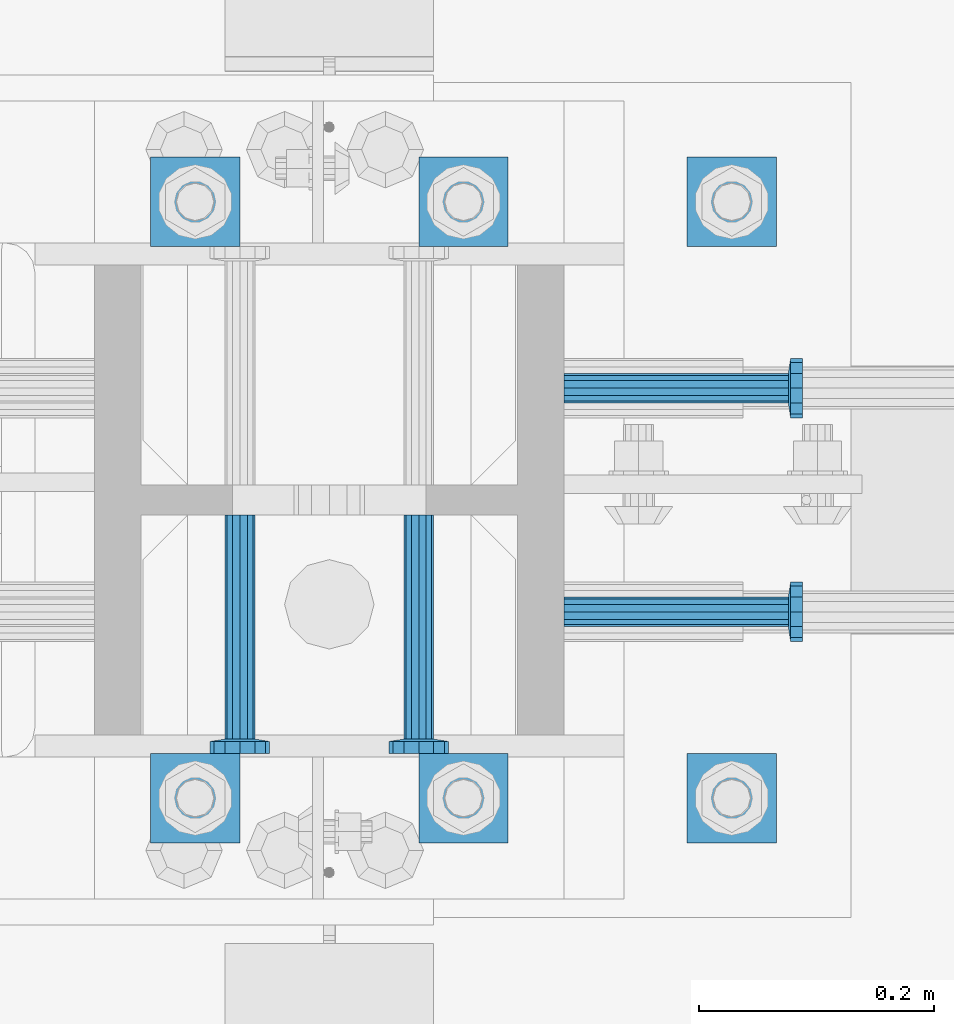
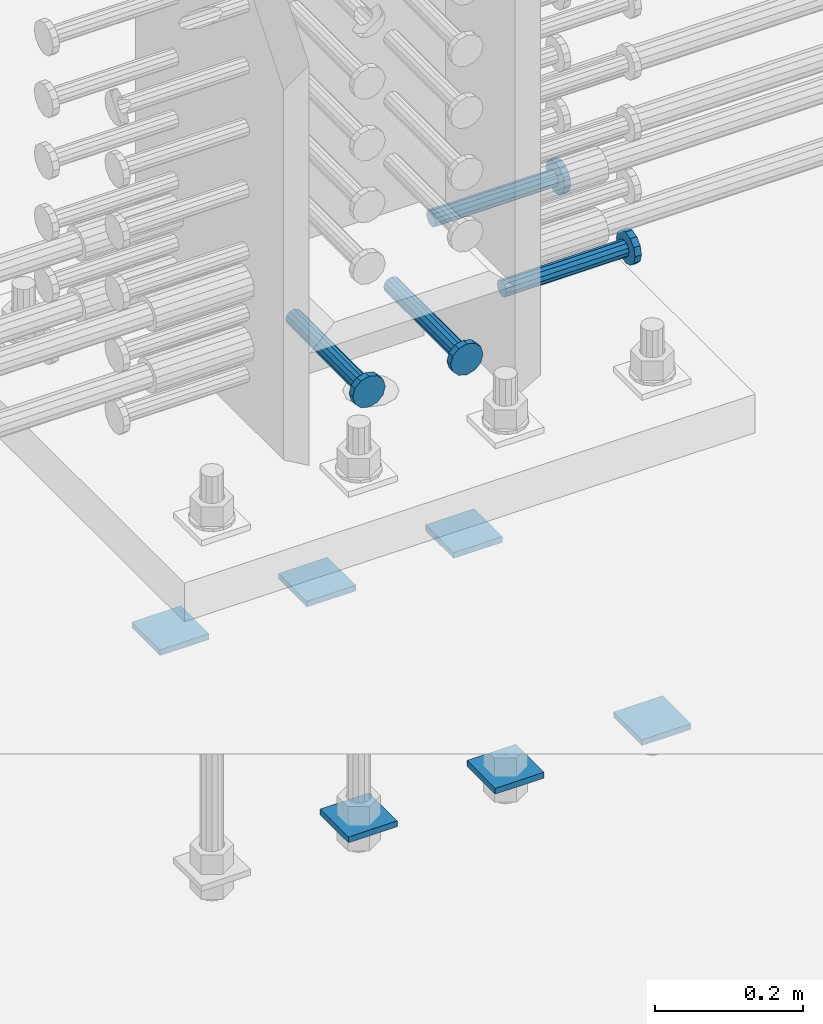
# One storey, part 1246 of 1763: 10 beams, 2 elements without a shape of their own.
"""IFC2X3 building model written with IfcOpenShell, lengths in millimetres."""

from ifc_helpers import new_model, si_unit, frame, origin_with_axes, place, context, subcontext, project, spatial, faceted_brep, material, type_object, element, aggregate, save


model = new_model("IFC2X3")

# Units and contexts
model_context = context("Model", 3, precision=1e-05, world=origin_with_axes())
body_context = subcontext(model_context, "Body", "Model", "MODEL_VIEW")
ifc_project = project(units=[si_unit("LENGTHUNIT", "METRE", prefix="MILLI"), si_unit("AREAUNIT", "SQUARE_METRE"), si_unit("VOLUMEUNIT", "CUBIC_METRE"), si_unit("MASSUNIT", "GRAM", prefix="KILO"), si_unit("TIMEUNIT", "SECOND"), si_unit("PLANEANGLEUNIT", "RADIAN"), si_unit("SOLIDANGLEUNIT", "STERADIAN"), si_unit("THERMODYNAMICTEMPERATUREUNIT", "DEGREE_CELSIUS"), si_unit("LUMINOUSINTENSITYUNIT", "LUMEN")], contexts=[model_context])

# Site, building, storey
site_placement = place(None, origin_with_axes())
site = spatial("IfcSite", under=ifc_project, at=site_placement, CompositionType="ELEMENT")
building_placement = place(site_placement, origin_with_axes())
building = spatial("IfcBuilding", under=site, at=building_placement, Name="Undefined", CompositionType="ELEMENT")
storey_placement = place(building_placement, origin_with_axes())
storey = spatial("IfcBuildingStorey", under=building, at=storey_placement, Name="Undefined", CompositionType="ELEMENT", Elevation=0.0)

# Assembly, beams
assembly_1_placement = place(storey_placement, origin_with_axes())
assembly_1 = element("IfcElementAssembly", 1, at=assembly_1_placement, inside=storey, Name="TEMPLATE", AssemblyPlace="NOTDEFINED", PredefinedType="RIGID_FRAME")
ifc_material_1 = material(Name="STEEL/A36")
beam_type_1 = type_object("IfcBeamType", PredefinedType="NOTDEFINED")
beam_1_placement = place(assembly_1_placement, frame((-34568.837273698, 203.199999999951, 3348.0375), z_axis=(0.0, 1.0, 0.0), x_axis=(-1.0, 0.0, 0.0)))
beam_1 = element("IfcBeam", 2, at=beam_1_placement, type_object=beam_type_1, material=ifc_material_1, Name="WASHER PLATE", context=body_context, shape_type="Brep", body=[
    faceted_brep([(0.0, 4.76249999999709, -38.1000000000004), (0.0, 4.76249999999709, 38.1000000000004), (76.2000000000007, 4.76249999999982, 38.0999999999985), (76.2000000000007, 4.76249999999982, -38.0999999999985), (0.0, -4.76249999999709, 38.1000000000004), (76.2000000000007, -4.76249999999982, 38.0999999999985), (0.0, -4.76249999999709, -38.1000000000004), (76.2000000000007, -4.76249999999982, -38.0999999999985)], [[[0, 1, 2, 3]], [[1, 4, 5, 2]], [[4, 6, 7, 5]], [[6, 0, 3, 7]], [[5, 7, 3, 2]], [[6, 4, 1, 0]]]),
])
beam_2_placement = place(assembly_1_placement, frame((-34568.837273698, 711.199999999951, 3348.0375), z_axis=(0.0, 1.0, 0.0), x_axis=(-1.0, 0.0, 0.0)))
beam_2 = element("IfcBeam", 3, at=beam_2_placement, type_object=beam_type_1, material=ifc_material_1, Name="WASHER PLATE", context=body_context, shape_type="Brep", body=[
    faceted_brep([(0.0, 4.76249999999709, -38.1000000000004), (0.0, 4.76249999999709, 38.1000000000004), (76.2000000000007, 4.76249999999982, 38.0999999999985), (76.2000000000007, 4.76249999999982, -38.0999999999985), (0.0, -4.76249999999709, 38.1000000000004), (76.2000000000007, -4.76249999999982, 38.0999999999985), (0.0, -4.76249999999709, -38.1000000000004), (76.2000000000007, -4.76249999999982, -38.0999999999985)], [[[0, 1, 2, 3]], [[1, 4, 5, 2]], [[4, 6, 7, 5]], [[6, 0, 3, 7]], [[5, 7, 3, 2]], [[6, 4, 1, 0]]]),
])
beam_3_placement = place(assembly_1_placement, frame((-34797.437273698, 203.199999999951, 3348.0375), z_axis=(0.0, 1.0, 0.0), x_axis=(-1.0, 0.0, 0.0)))
beam_3 = element("IfcBeam", 4, at=beam_3_placement, type_object=beam_type_1, material=ifc_material_1, Name="WASHER PLATE", context=body_context, shape_type="Brep", body=[
    faceted_brep([(0.0, 4.76249999999709, -38.1000000000004), (0.0, 4.76249999999709, 38.1000000000004), (76.2000000000007, 4.76249999999982, 38.0999999999985), (76.2000000000007, 4.76249999999982, -38.0999999999985), (0.0, -4.76249999999709, 38.1000000000004), (76.2000000000007, -4.76249999999982, 38.0999999999985), (0.0, -4.76249999999709, -38.1000000000004), (76.2000000000007, -4.76249999999982, -38.0999999999985)], [[[0, 1, 2, 3]], [[1, 4, 5, 2]], [[4, 6, 7, 5]], [[6, 0, 3, 7]], [[5, 7, 3, 2]], [[6, 4, 1, 0]]]),
])
beam_4_placement = place(assembly_1_placement, frame((-34797.437273698, 711.199999999951, 3348.0375), z_axis=(0.0, 1.0, 0.0), x_axis=(-1.0, 0.0, 0.0)))
beam_4 = element("IfcBeam", 5, at=beam_4_placement, type_object=beam_type_1, material=ifc_material_1, Name="WASHER PLATE", context=body_context, shape_type="Brep", body=[
    faceted_brep([(0.0, 4.76249999999709, -38.1000000000004), (0.0, 4.76249999999709, 38.1000000000004), (76.2000000000007, 4.76249999999982, 38.0999999999985), (76.2000000000007, 4.76249999999982, -38.0999999999985), (0.0, -4.76249999999709, 38.1000000000004), (76.2000000000007, -4.76249999999982, 38.0999999999985), (0.0, -4.76249999999709, -38.1000000000004), (76.2000000000007, -4.76249999999982, -38.0999999999985)], [[[0, 1, 2, 3]], [[1, 4, 5, 2]], [[4, 6, 7, 5]], [[6, 0, 3, 7]], [[5, 7, 3, 2]], [[6, 4, 1, 0]]]),
])
beam_5_placement = place(assembly_1_placement, frame((-35026.037273698, 203.199999999951, 3348.0375), z_axis=(0.0, 1.0, 0.0), x_axis=(-1.0, 0.0, 0.0)))
beam_5 = element("IfcBeam", 6, at=beam_5_placement, type_object=beam_type_1, material=ifc_material_1, Name="WASHER PLATE", context=body_context, shape_type="Brep", body=[
    faceted_brep([(0.0, 4.76249999999709, -38.1000000000004), (0.0, 4.76249999999709, 38.1000000000004), (76.2000000000007, 4.76249999999982, 38.0999999999985), (76.2000000000007, 4.76249999999982, -38.0999999999985), (0.0, -4.76249999999709, 38.1000000000004), (76.2000000000007, -4.76249999999982, 38.0999999999985), (0.0, -4.76249999999709, -38.1000000000004), (76.2000000000007, -4.76249999999982, -38.0999999999985)], [[[0, 1, 2, 3]], [[1, 4, 5, 2]], [[4, 6, 7, 5]], [[6, 0, 3, 7]], [[5, 7, 3, 2]], [[6, 4, 1, 0]]]),
])
beam_6_placement = place(assembly_1_placement, frame((-35026.037273698, 711.199999999951, 3348.0375), z_axis=(0.0, 1.0, 0.0), x_axis=(-1.0, 0.0, 0.0)))
beam_6 = element("IfcBeam", 7, at=beam_6_placement, type_object=beam_type_1, material=ifc_material_1, Name="WASHER PLATE", context=body_context, shape_type="Brep", body=[
    faceted_brep([(0.0, 4.76249999999709, -38.1000000000004), (0.0, 4.76249999999709, 38.1000000000004), (76.2000000000007, 4.76249999999982, 38.0999999999985), (76.2000000000007, 4.76249999999982, -38.0999999999985), (0.0, -4.76249999999709, 38.1000000000004), (76.2000000000007, -4.76249999999982, 38.0999999999985), (0.0, -4.76249999999709, -38.1000000000004), (76.2000000000007, -4.76249999999982, -38.0999999999985)], [[[0, 1, 2, 3]], [[1, 4, 5, 2]], [[4, 6, 7, 5]], [[6, 0, 3, 7]], [[5, 7, 3, 2]], [[6, 4, 1, 0]]]),
])
aggregate(assembly_1, [beam_1, beam_2, beam_3, beam_4, beam_5, beam_6])

assembly_2_placement = place(storey_placement, origin_with_axes())
assembly_2 = element("IfcElementAssembly", 8, at=assembly_2_placement, inside=storey, Name="COLUMN", AssemblyPlace="NOTDEFINED", PredefinedType="RIGID_FRAME")
ifc_material_2 = material(Name="STEEL/A108")
beam_type_2 = type_object("IfcBeamType", PredefinedType="NOTDEFINED")
beam_7_placement = place(assembly_2_placement, frame((-35026.0372733561, 444.499999885675, 4013.2), z_axis=(1.0, 0.0, 0.0), x_axis=(0.0, -1.0, 0.0)))
beam_7 = element("IfcBeam", 9, at=beam_7_placement, type_object=beam_type_2, material=ifc_material_2, Name="HEADED STUD ANCHOR", context=body_context, shape_type="Brep", body=[
    faceted_brep([(0.0, -12.6999999999971, -1.81898940354586e-12), (3.63797880709171e-12, -11.0, -6.34999990463257), (191.00799999576, -11.0, -6.34999990454889), (191.007999995752, -12.6999998092651, 8.36735125631094e-11), (7.27595761418343e-12, -6.34999990463257, -11.0), (191.00799999576, -6.34999990463257, -10.9999999999163), (3.63797880709171e-12, 0.0, -12.6999998092651), (191.00799999576, 0.0, -12.6999998091815), (7.27595761418343e-12, 6.34999990463257, -11.0), (191.00799999576, 6.34999990463257, -10.9999999999163), (3.63797880709171e-12, 11.0, -6.34999990463257), (191.00799999576, 11.0, -6.34999990454889), (0.0, 12.6999999999971, -1.81898940354586e-12), (191.007999995752, 12.6999998092651, 8.36735125631094e-11), (0.0, 11.0, 6.34999990463257), (191.007999995752, 11.0, 6.34999990471624), (-3.63797880709171e-12, 6.34999990463257, 11.0), (191.007999995749, 6.34999990463257, 11.0000000000837), (-3.63797880709171e-12, 0.0, 12.6999998092651), (191.007999995749, 0.0, 12.6999998093488), (-3.63797880709171e-12, -6.34999990463257, 11.0), (191.007999995749, -6.34999990463257, 11.0000000000837), (0.0, -11.0, 6.34999990463257), (191.007999995752, -11.0, 6.34999990471624), (193.039999995715, -22.0, -12.6999998091796), (193.039999995708, -25.3999996185303, 8.54925019666553e-11), (193.039999995719, -12.6999998092651, -21.9999999999145), (193.039999995719, 0.0, -25.3999996184448), (193.039999995719, 12.6999998092651, -21.9999999999145), (193.039999995715, 22.0, -12.6999998091796), (193.039999995708, 25.3999996185303, 8.54925019666553e-11), (193.039999995704, 22.0, 12.6999998093506), (193.039999995701, 12.6999998092651, 22.0000000000855), (193.039999995697, 0.0, 25.3999996186158), (193.039999995701, -12.6999998092651, 22.0000000000855), (193.039999995704, -22.0, 12.6999998093506), (203.199999995486, -22.0, -12.6999998091742), (203.199999995482, -25.3999996185303, 9.09494701772928e-11), (203.199999995493, -12.6999998092651, -21.9999999999091), (203.199999995493, 0.0, -25.3999996184393), (203.199999995493, 12.6999998092651, -21.9999999999091), (203.199999995486, 22.0, -12.6999998091742), (203.199999995482, 25.3999996185303, 9.09494701772928e-11), (203.199999995479, 22.0, 12.6999998093561), (203.199999995475, 12.6999998092651, 22.0000000000909), (203.199999995471, 0.0, 25.3999996186212), (203.199999995475, -12.6999998092651, 22.0000000000909), (203.199999995479, -22.0, 12.6999998093561)], [[[0, 1, 2, 3]], [[1, 4, 5, 2]], [[4, 6, 7, 5]], [[6, 8, 9, 7]], [[8, 10, 11, 9]], [[10, 12, 13, 11]], [[12, 14, 15, 13]], [[14, 16, 17, 15]], [[16, 18, 19, 17]], [[18, 20, 21, 19]], [[20, 22, 23, 21]], [[22, 0, 3, 23]], [[22, 20, 18, 16, 14, 12, 10, 8, 6, 4, 1, 0]], [[3, 2, 24, 25]], [[2, 5, 26, 24]], [[5, 7, 27, 26]], [[7, 9, 28, 27]], [[9, 11, 29, 28]], [[11, 13, 30, 29]], [[13, 15, 31, 30]], [[15, 17, 32, 31]], [[17, 19, 33, 32]], [[19, 21, 34, 33]], [[21, 23, 35, 34]], [[23, 3, 25, 35]], [[25, 24, 36, 37]], [[24, 26, 38, 36]], [[26, 27, 39, 38]], [[27, 28, 40, 39]], [[28, 29, 41, 40]], [[29, 30, 42, 41]], [[30, 31, 43, 42]], [[31, 32, 44, 43]], [[32, 33, 45, 44]], [[33, 34, 46, 45]], [[34, 35, 47, 46]], [[35, 25, 37, 47]], [[38, 39, 40, 41, 42, 43, 44, 45, 46, 47, 37, 36]]]),
])
beam_8_placement = place(assembly_2_placement, frame((-34873.637273357, 444.499999999951, 4013.2), z_axis=(1.0, 0.0, 0.0), x_axis=(0.0, -1.0, 0.0)))
beam_8 = element("IfcBeam", 10, at=beam_8_placement, type_object=beam_type_2, material=ifc_material_2, Name="HEADED STUD ANCHOR", context=body_context, shape_type="Brep", body=[
    faceted_brep([(0.0, -12.6999999999971, -1.81898940354586e-12), (3.63797880709171e-12, -11.0, -6.34999990463257), (191.00799999576, -11.0, -6.34999990454889), (191.007999995752, -12.6999998092651, 8.36735125631094e-11), (7.27595761418343e-12, -6.34999990463257, -11.0), (191.00799999576, -6.34999990463257, -10.9999999999163), (3.63797880709171e-12, 0.0, -12.6999998092651), (191.00799999576, 0.0, -12.6999998091815), (7.27595761418343e-12, 6.34999990463257, -11.0), (191.00799999576, 6.34999990463257, -10.9999999999163), (3.63797880709171e-12, 11.0, -6.34999990463257), (191.00799999576, 11.0, -6.34999990454889), (0.0, 12.6999999999971, -1.81898940354586e-12), (191.007999995752, 12.6999998092651, 8.36735125631094e-11), (0.0, 11.0, 6.34999990463257), (191.007999995752, 11.0, 6.34999990471624), (-3.63797880709171e-12, 6.34999990463257, 11.0), (191.007999995749, 6.34999990463257, 11.0000000000837), (-3.63797880709171e-12, 0.0, 12.6999998092651), (191.007999995749, 0.0, 12.6999998093488), (-3.63797880709171e-12, -6.34999990463257, 11.0), (191.007999995749, -6.34999990463257, 11.0000000000837), (0.0, -11.0, 6.34999990463257), (191.007999995752, -11.0, 6.34999990471624), (193.039999995715, -22.0, -12.6999998091796), (193.039999995708, -25.3999996185303, 8.54925019666553e-11), (193.039999995719, -12.6999998092651, -21.9999999999145), (193.039999995719, 0.0, -25.3999996184448), (193.039999995719, 12.6999998092651, -21.9999999999145), (193.039999995715, 22.0, -12.6999998091796), (193.039999995708, 25.3999996185303, 8.54925019666553e-11), (193.039999995704, 22.0, 12.6999998093506), (193.039999995701, 12.6999998092651, 22.0000000000855), (193.039999995697, 0.0, 25.3999996186158), (193.039999995701, -12.6999998092651, 22.0000000000855), (193.039999995704, -22.0, 12.6999998093506), (203.199999995486, -22.0, -12.6999998091742), (203.199999995482, -25.3999996185303, 9.09494701772928e-11), (203.199999995493, -12.6999998092651, -21.9999999999091), (203.199999995493, 0.0, -25.3999996184393), (203.199999995493, 12.6999998092651, -21.9999999999091), (203.199999995486, 22.0, -12.6999998091742), (203.199999995482, 25.3999996185303, 9.09494701772928e-11), (203.199999995479, 22.0, 12.6999998093561), (203.199999995475, 12.6999998092651, 22.0000000000909), (203.199999995471, 0.0, 25.3999996186212), (203.199999995475, -12.6999998092651, 22.0000000000909), (203.199999995479, -22.0, 12.6999998093561)], [[[0, 1, 2, 3]], [[1, 4, 5, 2]], [[4, 6, 7, 5]], [[6, 8, 9, 7]], [[8, 10, 11, 9]], [[10, 12, 13, 11]], [[12, 14, 15, 13]], [[14, 16, 17, 15]], [[16, 18, 19, 17]], [[18, 20, 21, 19]], [[20, 22, 23, 21]], [[22, 0, 3, 23]], [[22, 20, 18, 16, 14, 12, 10, 8, 6, 4, 1, 0]], [[3, 2, 24, 25]], [[2, 5, 26, 24]], [[5, 7, 27, 26]], [[7, 9, 28, 27]], [[9, 11, 29, 28]], [[11, 13, 30, 29]], [[13, 15, 31, 30]], [[15, 17, 32, 31]], [[17, 19, 33, 32]], [[19, 21, 34, 33]], [[21, 23, 35, 34]], [[23, 3, 25, 35]], [[25, 24, 36, 37]], [[24, 26, 38, 36]], [[26, 27, 39, 38]], [[27, 28, 40, 39]], [[28, 29, 41, 40]], [[29, 30, 42, 41]], [[30, 31, 43, 42]], [[31, 32, 44, 43]], [[32, 33, 45, 44]], [[33, 34, 46, 45]], [[34, 35, 47, 46]], [[35, 25, 37, 47]], [[38, 39, 40, 41, 42, 43, 44, 45, 46, 47, 37, 36]]]),
])
beam_9_placement = place(assembly_2_placement, frame((-34749.8119785861, 361.950000000554, 4013.2), z_axis=(0.0, 1.0, 0.0), x_axis=(1.0, 0.0, 0.0)))
beam_9 = element("IfcBeam", 11, at=beam_9_placement, type_object=beam_type_2, material=ifc_material_2, Name="HEADED STUD ANCHOR", context=body_context, shape_type="Brep", body=[
    faceted_brep([(0.0, -12.6999999999971, -1.81898940354586e-12), (3.63797880709171e-12, -11.0, -6.34999990463257), (191.00799999576, -11.0, -6.34999990454889), (191.007999995752, -12.6999998092651, 8.36735125631094e-11), (7.27595761418343e-12, -6.34999990463257, -11.0), (191.00799999576, -6.34999990463257, -10.9999999999163), (3.63797880709171e-12, 0.0, -12.6999998092651), (191.00799999576, 0.0, -12.6999998091815), (7.27595761418343e-12, 6.34999990463257, -11.0), (191.00799999576, 6.34999990463257, -10.9999999999163), (3.63797880709171e-12, 11.0, -6.34999990463257), (191.00799999576, 11.0, -6.34999990454889), (0.0, 12.6999999999971, -1.81898940354586e-12), (191.007999995752, 12.6999998092651, 8.36735125631094e-11), (0.0, 11.0, 6.34999990463257), (191.007999995752, 11.0, 6.34999990471624), (-3.63797880709171e-12, 6.34999990463257, 11.0), (191.007999995749, 6.34999990463257, 11.0000000000837), (-3.63797880709171e-12, 0.0, 12.6999998092651), (191.007999995749, 0.0, 12.6999998093488), (-3.63797880709171e-12, -6.34999990463257, 11.0), (191.007999995749, -6.34999990463257, 11.0000000000837), (0.0, -11.0, 6.34999990463257), (191.007999995752, -11.0, 6.34999990471624), (193.039999995715, -22.0, -12.6999998091796), (193.039999995708, -25.3999996185303, 8.54925019666553e-11), (193.039999995719, -12.6999998092651, -21.9999999999145), (193.039999995719, 0.0, -25.3999996184448), (193.039999995719, 12.6999998092651, -21.9999999999145), (193.039999995715, 22.0, -12.6999998091796), (193.039999995708, 25.3999996185303, 8.54925019666553e-11), (193.039999995704, 22.0, 12.6999998093506), (193.039999995701, 12.6999998092651, 22.0000000000855), (193.039999995697, 0.0, 25.3999996186158), (193.039999995701, -12.6999998092651, 22.0000000000855), (193.039999995704, -22.0, 12.6999998093506), (203.199999995486, -22.0, -12.6999998091742), (203.199999995482, -25.3999996185303, 9.09494701772928e-11), (203.199999995493, -12.6999998092651, -21.9999999999091), (203.199999995493, 0.0, -25.3999996184393), (203.199999995493, 12.6999998092651, -21.9999999999091), (203.199999995486, 22.0, -12.6999998091742), (203.199999995482, 25.3999996185303, 9.09494701772928e-11), (203.199999995479, 22.0, 12.6999998093561), (203.199999995475, 12.6999998092651, 22.0000000000909), (203.199999995471, 0.0, 25.3999996186212), (203.199999995475, -12.6999998092651, 22.0000000000909), (203.199999995479, -22.0, 12.6999998093561)], [[[0, 1, 2, 3]], [[1, 4, 5, 2]], [[4, 6, 7, 5]], [[6, 8, 9, 7]], [[8, 10, 11, 9]], [[10, 12, 13, 11]], [[12, 14, 15, 13]], [[14, 16, 17, 15]], [[16, 18, 19, 17]], [[18, 20, 21, 19]], [[20, 22, 23, 21]], [[22, 0, 3, 23]], [[22, 20, 18, 16, 14, 12, 10, 8, 6, 4, 1, 0]], [[3, 2, 24, 25]], [[2, 5, 26, 24]], [[5, 7, 27, 26]], [[7, 9, 28, 27]], [[9, 11, 29, 28]], [[11, 13, 30, 29]], [[13, 15, 31, 30]], [[15, 17, 32, 31]], [[17, 19, 33, 32]], [[19, 21, 34, 33]], [[21, 23, 35, 34]], [[23, 3, 25, 35]], [[25, 24, 36, 37]], [[24, 26, 38, 36]], [[26, 27, 39, 38]], [[27, 28, 40, 39]], [[28, 29, 41, 40]], [[29, 30, 42, 41]], [[30, 31, 43, 42]], [[31, 32, 44, 43]], [[32, 33, 45, 44]], [[33, 34, 46, 45]], [[34, 35, 47, 46]], [[35, 25, 37, 47]], [[38, 39, 40, 41, 42, 43, 44, 45, 46, 47, 37, 36]]]),
])
beam_10_placement = place(assembly_2_placement, frame((-34749.8119099256, 552.449999999943, 4013.2), z_axis=(0.0, 1.0, 0.0), x_axis=(1.0, 0.0, 0.0)))
beam_10 = element("IfcBeam", 12, at=beam_10_placement, type_object=beam_type_2, material=ifc_material_2, Name="HEADED STUD ANCHOR", context=body_context, shape_type="Brep", body=[
    faceted_brep([(0.0, -12.6999999999971, -1.81898940354586e-12), (3.63797880709171e-12, -11.0, -6.34999990463257), (191.00799999576, -11.0, -6.34999990454889), (191.007999995752, -12.6999998092651, 8.36735125631094e-11), (7.27595761418343e-12, -6.34999990463257, -11.0), (191.00799999576, -6.34999990463257, -10.9999999999163), (3.63797880709171e-12, 0.0, -12.6999998092651), (191.00799999576, 0.0, -12.6999998091815), (7.27595761418343e-12, 6.34999990463257, -11.0), (191.00799999576, 6.34999990463257, -10.9999999999163), (3.63797880709171e-12, 11.0, -6.34999990463257), (191.00799999576, 11.0, -6.34999990454889), (0.0, 12.6999999999971, -1.81898940354586e-12), (191.007999995752, 12.6999998092651, 8.36735125631094e-11), (0.0, 11.0, 6.34999990463257), (191.007999995752, 11.0, 6.34999990471624), (-3.63797880709171e-12, 6.34999990463257, 11.0), (191.007999995749, 6.34999990463257, 11.0000000000837), (-3.63797880709171e-12, 0.0, 12.6999998092651), (191.007999995749, 0.0, 12.6999998093488), (-3.63797880709171e-12, -6.34999990463257, 11.0), (191.007999995749, -6.34999990463257, 11.0000000000837), (0.0, -11.0, 6.34999990463257), (191.007999995752, -11.0, 6.34999990471624), (193.039999995715, -22.0, -12.6999998091796), (193.039999995708, -25.3999996185303, 8.54925019666553e-11), (193.039999995719, -12.6999998092651, -21.9999999999145), (193.039999995719, 0.0, -25.3999996184448), (193.039999995719, 12.6999998092651, -21.9999999999145), (193.039999995715, 22.0, -12.6999998091796), (193.039999995708, 25.3999996185303, 8.54925019666553e-11), (193.039999995704, 22.0, 12.6999998093506), (193.039999995701, 12.6999998092651, 22.0000000000855), (193.039999995697, 0.0, 25.3999996186158), (193.039999995701, -12.6999998092651, 22.0000000000855), (193.039999995704, -22.0, 12.6999998093506), (203.199999995486, -22.0, -12.6999998091742), (203.199999995482, -25.3999996185303, 9.09494701772928e-11), (203.199999995493, -12.6999998092651, -21.9999999999091), (203.199999995493, 0.0, -25.3999996184393), (203.199999995493, 12.6999998092651, -21.9999999999091), (203.199999995486, 22.0, -12.6999998091742), (203.199999995482, 25.3999996185303, 9.09494701772928e-11), (203.199999995479, 22.0, 12.6999998093561), (203.199999995475, 12.6999998092651, 22.0000000000909), (203.199999995471, 0.0, 25.3999996186212), (203.199999995475, -12.6999998092651, 22.0000000000909), (203.199999995479, -22.0, 12.6999998093561)], [[[0, 1, 2, 3]], [[1, 4, 5, 2]], [[4, 6, 7, 5]], [[6, 8, 9, 7]], [[8, 10, 11, 9]], [[10, 12, 13, 11]], [[12, 14, 15, 13]], [[14, 16, 17, 15]], [[16, 18, 19, 17]], [[18, 20, 21, 19]], [[20, 22, 23, 21]], [[22, 0, 3, 23]], [[22, 20, 18, 16, 14, 12, 10, 8, 6, 4, 1, 0]], [[3, 2, 24, 25]], [[2, 5, 26, 24]], [[5, 7, 27, 26]], [[7, 9, 28, 27]], [[9, 11, 29, 28]], [[11, 13, 30, 29]], [[13, 15, 31, 30]], [[15, 17, 32, 31]], [[17, 19, 33, 32]], [[19, 21, 34, 33]], [[21, 23, 35, 34]], [[23, 3, 25, 35]], [[25, 24, 36, 37]], [[24, 26, 38, 36]], [[26, 27, 39, 38]], [[27, 28, 40, 39]], [[28, 29, 41, 40]], [[29, 30, 42, 41]], [[30, 31, 43, 42]], [[31, 32, 44, 43]], [[32, 33, 45, 44]], [[33, 34, 46, 45]], [[34, 35, 47, 46]], [[35, 25, 37, 47]], [[38, 39, 40, 41, 42, 43, 44, 45, 46, 47, 37, 36]]]),
])
aggregate(assembly_2, [beam_7, beam_8, beam_9, beam_10])

save(model, "model.ifc")
